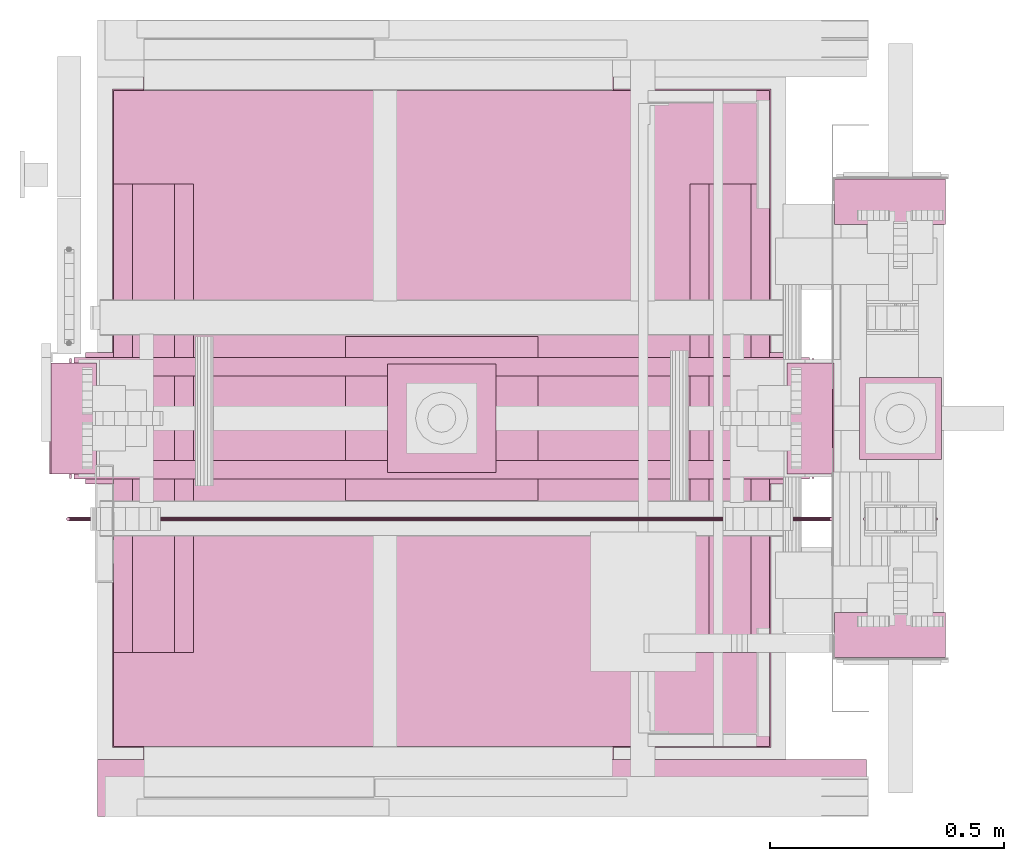
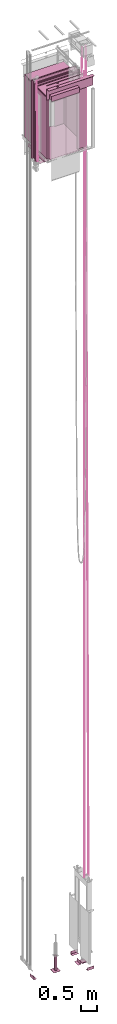
# One storey, part 4 of 13: 5 transport elements.
"""IFC4 building model written with IfcOpenShell, lengths in millimetres."""

from ifc_helpers import new_model, entity, si_unit, converted_unit, frame, origin_with_axes, place, context, subcontext, project, spatial, faceted_brep, element, save


model = new_model("IFC4")

# Units and contexts
context_of_model = context(None, 3, precision=0.01, world=origin_with_axes())
sub_context_1 = subcontext(context_of_model, None, None, "MODEL_VIEW")
sub_context_2 = subcontext(context_of_model, None, None, "MODEL_VIEW")
sub_context_3 = subcontext(context_of_model, None, None, "MODEL_VIEW")
sub_context_4 = subcontext(context_of_model, None, None, "MODEL_VIEW")
sub_context_5 = subcontext(context_of_model, None, None, "MODEL_VIEW")
ifc_project = project(units=[converted_unit("PLANEANGLEUNIT", "degree", entity("IfcPlaneAngleMeasure", 0.017453292519943), si_unit("PLANEANGLEUNIT", "RADIAN"), dimensions=[0, 0, 0, 0, 0, 0, 0]), si_unit("LENGTHUNIT", "METRE", prefix="MILLI"), si_unit("MASSUNIT", "GRAM", prefix="KILO"), converted_unit("TIMEUNIT", "year", entity("IfcTimeMeasure", 31557600.0), si_unit("TIMEUNIT", "SECOND"), dimensions=[0, 0, 1, 0, 0, 0, 0]), si_unit("THERMODYNAMICTEMPERATUREUNIT", "DEGREE_CELSIUS"), si_unit("AREAUNIT", "SQUARE_METRE"), si_unit("FORCEUNIT", "NEWTON"), si_unit("VOLUMEUNIT", "CUBIC_METRE"), si_unit("PRESSUREUNIT", "PASCAL"), si_unit("SOLIDANGLEUNIT", "STERADIAN")], contexts=[context_of_model])

# Site, building, storey
site = spatial("IfcSite", under=ifc_project)
building = spatial("IfcBuilding", under=site, Name="Document")
placement = place(None, origin_with_axes())
storey_placement = place(placement, frame((0.0, 0.0, -26400.0), z_axis=(0.0, 0.0, 1.0), x_axis=(1.0, 0.0, 0.0)))
storey = spatial("IfcBuildingStorey", under=building, at=storey_placement, Name="Z -26400", Elevation=-26400.0)

# Transport elements
transport_element_1_placement = place(storey_placement, frame((900.0, 1025.0, 31219.0), z_axis=(0.0, 0.0, 1.0), x_axis=(1.0, 0.0, 0.0)))
element("IfcTransportElement", 1, at=transport_element_1_placement, inside=storey, ObjectType="Car", PredefinedType="ELEVATOR", context=sub_context_1, shape_type="Brep", body=[
    faceted_brep([(700.0, -700.0, 2300.0), (700.0, 700.0, 2300.0), (700.0, 700.0, 2350.0), (700.0, -700.0, 2350.0), (-700.0, -700.0, 2300.0), (-700.0, -700.0, 2350.0), (-700.0, 700.0, 2350.0), (-700.0, 700.0, 2300.0)], [[[0, 1, 2, 3]], [[4, 5, 6, 7]], [[0, 3, 5, 4]], [[3, 2, 6, 5]], [[2, 1, 7, 6]], [[1, 0, 4, 7]]]),
    faceted_brep([(-636.5, -703.0, 4.0), (-636.5, -703.0, 2300.0), (-703.0, -703.0, 2300.0), (-703.0, -703.0, 4.0), (-703.0, 703.0, 4.0), (-636.5, 703.0, 4.0), (-636.5, 700.0, 4.0), (-700.0, 700.0, 4.0), (-700.0, -700.0, 4.0), (-636.5, -700.0, 4.0), (-703.0, 703.0, 2300.0), (-700.0, -700.0, 2300.0), (-636.5, -700.0, 2300.0), (-700.0, 700.0, 2300.0), (-636.5, 703.0, 2300.0), (-636.5, 700.0, 2300.0)], [[[0, 1, 2, 3]], [[4, 5, 6, 7, 8, 9, 0, 3]], [[2, 10, 4, 3]], [[11, 12, 9, 8]], [[7, 13, 11, 8]], [[9, 12, 1, 0]], [[10, 14, 5, 4]], [[6, 15, 13, 7]], [[5, 14, 15, 6]], [[1, 12, 11, 13, 15, 14, 10, 2]]]),
    faceted_brep([(366.5, -700.0, 4.0), (700.0, -700.0, 4.0), (700.0, 700.0, 4.0), (366.5, 700.0, 4.0), (366.5, 703.0, 4.0), (703.0, 703.0, 4.0), (703.0, -703.0, 4.0), (366.5, -703.0, 4.0), (366.5, -703.0, 2300.0), (366.5, -700.0, 2300.0), (703.0, -703.0, 2300.0), (700.0, -700.0, 2300.0), (700.0, 700.0, 2300.0), (703.0, 703.0, 2300.0), (366.5, 700.0, 2300.0), (366.5, 703.0, 2300.0)], [[[0, 1, 2, 3, 4, 5, 6, 7]], [[8, 9, 0, 7]], [[6, 10, 8, 7]], [[9, 11, 1, 0]], [[11, 12, 2, 1]], [[5, 13, 10, 6]], [[14, 15, 4, 3]], [[2, 12, 14, 3]], [[15, 13, 5, 4]], [[10, 13, 15, 14, 12, 11, 9, 8]]]),
    faceted_brep([(-701.5, -701.5, 4.0), (-701.5, 701.5, 4.0), (-701.5, 701.5, 0.0), (-701.5, -701.5, 0.0), (-636.5, -766.5, 4.0), (-636.5, -701.5, 4.0), (-636.5, -701.5, 0.0), (-636.5, -766.5, 0.0), (-636.5, 701.5, 4.0), (-636.5, 766.5, 4.0), (-636.5, 766.5, 0.0), (-636.5, 701.5, 0.0), (366.5, -701.5, 0.0), (366.5, -701.5, 4.0), (366.5, -766.5, 4.0), (366.5, -766.5, 0.0), (701.5, 701.5, 0.0), (701.5, 701.5, 4.0), (701.5, -701.5, 4.0), (701.5, -701.5, 0.0), (366.5, 766.5, 0.0), (366.5, 766.5, 4.0), (366.5, 701.5, 4.0), (366.5, 701.5, 0.0)], [[[0, 1, 2, 3]], [[4, 5, 6, 7]], [[8, 9, 10, 11]], [[12, 13, 14, 15]], [[16, 17, 18, 19]], [[20, 21, 22, 23]], [[6, 5, 0, 3]], [[15, 14, 4, 7]], [[1, 8, 11, 2]], [[9, 21, 20, 10]], [[19, 18, 13, 12]], [[22, 17, 16, 23]], [[2, 11, 10, 20, 23, 16, 19, 12, 15, 7, 6, 3]], [[5, 4, 14, 13, 18, 17, 22, 21, 9, 8, 1, 0]]]),
])
transport_element_2_placement = place(storey_placement, origin_with_axes())
element("IfcTransportElement", 2, at=transport_element_2_placement, inside=storey, PredefinedType="ELEVATOR", context=sub_context_2, shape_type="Brep", body=[
    faceted_brep([(1647.1722412109375, 807.1715698242188, 30872.0625), (1728.6722412109375, 807.1715698242188, 34609.0625), (1727.805419921875, 808.46923828125, 34609.08203125), (1646.305419921875, 808.46923828125, 30872.080078125), (1646.0009765625, 810.0, 30872.087890625), (1646.305419921875, 811.53076171875, 30872.080078125), (1647.1722412109375, 812.8284301757812, 30872.0625), (1648.4696044921875, 813.6954956054688, 30872.033203125), (1650.0, 814.0, 30872.0), (1651.5303955078125, 813.6954956054688, 30871.966796875), (1652.8277587890625, 812.8284301757812, 30871.9375), (1653.694580078125, 811.53076171875, 30871.919921875), (1653.9990234375, 810.0, 30871.912109375), (1653.694580078125, 808.46923828125, 30871.919921875), (1652.8277587890625, 807.1715698242188, 30871.9375), (1651.5303955078125, 806.3045043945312, 30871.966796875), (1650.0, 806.0, 30872.0), (1648.4696044921875, 806.3045043945312, 30872.033203125), (1727.5009765625, 810.0, 34609.0859375), (1729.9696044921875, 806.3045043945312, 34609.03515625), (1727.805419921875, 811.53076171875, 34609.08203125), (1731.5, 806.0, 34609.0), (1728.6722412109375, 812.8284301757812, 34609.0625), (1733.0303955078125, 806.3045043945312, 34608.96484375), (1729.9696044921875, 813.6954956054688, 34609.03515625), (1734.3277587890625, 807.1715698242188, 34608.9375), (1731.5, 814.0, 34609.0), (1735.194580078125, 808.46923828125, 34608.91796875), (1733.0303955078125, 813.6954956054688, 34608.96484375), (1735.4990234375, 810.0, 34608.9140625), (1734.3277587890625, 812.8284301757812, 34608.9375), (1735.194580078125, 811.53076171875, 34608.91796875)], [[[0, 1, 2, 3]], [[4, 5, 6, 7, 8, 9, 10, 11, 12, 13, 14, 15, 16, 17, 0, 3]], [[2, 18, 4, 3]], [[17, 19, 1, 0]], [[18, 20, 5, 4]], [[16, 21, 19, 17]], [[20, 22, 6, 5]], [[15, 23, 21, 16]], [[22, 24, 7, 6]], [[14, 25, 23, 15]], [[24, 26, 8, 7]], [[13, 27, 25, 14]], [[26, 28, 9, 8]], [[12, 29, 27, 13]], [[28, 30, 10, 9]], [[11, 31, 29, 12]], [[30, 31, 11, 10]], [[1, 19, 21, 23, 25, 27, 29, 31, 30, 28, 26, 24, 22, 20, 18, 2]]]),
    faceted_brep([(1801.171630859375, 807.1715698242188, 3329.0), (1801.171630859375, 807.1715698242188, 33674.0), (1800.304443359375, 808.46923828125, 33674.0), (1800.304443359375, 808.46923828125, 3329.0), (1800.0, 810.0, 3329.0), (1800.304443359375, 811.53076171875, 3329.0), (1801.171630859375, 812.8284301757812, 3329.0), (1802.46923828125, 813.6954956054688, 3329.0), (1804.0, 814.0, 3329.0), (1805.53076171875, 813.6954956054688, 3329.0), (1806.828369140625, 812.8284301757812, 3329.0), (1807.695556640625, 811.53076171875, 3329.0), (1808.0, 810.0, 3329.0), (1807.695556640625, 808.46923828125, 3329.0), (1806.828369140625, 807.1715698242188, 3329.0), (1805.53076171875, 806.3045043945312, 3329.0), (1804.0, 806.0, 3329.0), (1802.46923828125, 806.3045043945312, 3329.0), (1800.0, 810.0, 33674.0), (1802.46923828125, 806.3045043945312, 33674.0), (1800.304443359375, 811.53076171875, 33674.0), (1804.0, 806.0, 33674.0), (1801.171630859375, 812.8284301757812, 33674.0), (1805.53076171875, 806.3045043945312, 33674.0), (1802.46923828125, 813.6954956054688, 33674.0), (1806.828369140625, 807.1715698242188, 33674.0), (1804.0, 814.0, 33674.0), (1807.695556640625, 808.46923828125, 33674.0), (1805.53076171875, 813.6954956054688, 33674.0), (1808.0, 810.0, 33674.0), (1806.828369140625, 812.8284301757812, 33674.0), (1807.695556640625, 811.53076171875, 33674.0)], [[[0, 1, 2, 3]], [[4, 5, 6, 7, 8, 9, 10, 11, 12, 13, 14, 15, 16, 17, 0, 3]], [[2, 18, 4, 3]], [[17, 19, 1, 0]], [[18, 20, 5, 4]], [[16, 21, 19, 17]], [[20, 22, 6, 5]], [[15, 23, 21, 16]], [[22, 24, 7, 6]], [[14, 25, 23, 15]], [[24, 26, 8, 7]], [[13, 27, 25, 14]], [[26, 28, 9, 8]], [[12, 29, 27, 13]], [[28, 30, 10, 9]], [[11, 31, 29, 12]], [[30, 31, 11, 10]], [[1, 19, 21, 23, 25, 27, 29, 31, 30, 28, 26, 24, 22, 20, 18, 2]]]),
    faceted_brep([(1951.171630859375, 807.1715698242188, 3328.9912109375), (1853.671630859375, 807.1715698242188, 34608.9921875), (1852.804443359375, 808.46923828125, 34608.98828125), (1950.304443359375, 808.46923828125, 3328.988525390625), (1950.0, 810.0, 3328.987548828125), (1950.304443359375, 811.53076171875, 3328.988525390625), (1951.171630859375, 812.8284301757812, 3328.9912109375), (1952.46923828125, 813.6954956054688, 3328.9951171875), (1954.0, 814.0, 3329.0), (1955.53076171875, 813.6954956054688, 3329.0048828125), (1956.828369140625, 812.8284301757812, 3329.0087890625), (1957.695556640625, 811.53076171875, 3329.011474609375), (1958.0, 810.0, 3329.012451171875), (1957.695556640625, 808.46923828125, 3329.011474609375), (1956.828369140625, 807.1715698242188, 3329.0087890625), (1955.53076171875, 806.3045043945312, 3329.0048828125), (1954.0, 806.0, 3329.0), (1952.46923828125, 806.3045043945312, 3328.9951171875), (1854.96923828125, 806.3045043945312, 34608.99609375), (1852.5, 810.0, 34608.98828125), (1852.804443359375, 811.53076171875, 34608.98828125), (1856.5, 806.0, 34609.0), (1853.671630859375, 812.8284301757812, 34608.9921875), (1858.03076171875, 806.3045043945312, 34609.00390625), (1854.96923828125, 813.6954956054688, 34608.99609375), (1859.328369140625, 807.1715698242188, 34609.0078125), (1856.5, 814.0, 34609.0), (1860.195556640625, 808.46923828125, 34609.01171875), (1858.03076171875, 813.6954956054688, 34609.00390625), (1860.5, 810.0, 34609.01171875), (1859.328369140625, 812.8284301757812, 34609.0078125), (1860.195556640625, 811.53076171875, 34609.01171875)], [[[0, 1, 2, 3]], [[4, 5, 6, 7, 8, 9, 10, 11, 12, 13, 14, 15, 16, 17, 0, 3]], [[17, 18, 1, 0]], [[2, 19, 4, 3]], [[19, 20, 5, 4]], [[16, 21, 18, 17]], [[20, 22, 6, 5]], [[15, 23, 21, 16]], [[22, 24, 7, 6]], [[14, 25, 23, 15]], [[24, 26, 8, 7]], [[13, 27, 25, 14]], [[26, 28, 9, 8]], [[12, 29, 27, 13]], [[28, 30, 10, 9]], [[30, 31, 11, 10]], [[11, 31, 29, 12]], [[1, 18, 21, 23, 25, 27, 29, 31, 30, 28, 26, 24, 22, 20, 19, 2]]]),
    faceted_brep([(147.1719207763672, 807.1715698242188, 30871.955078125), (100.17192077636719, 807.1715698242188, 33883.95703125), (99.304931640625, 808.46923828125, 33883.94140625), (146.304931640625, 808.46923828125, 30871.94140625), (146.00048828125, 810.0, 30871.9375), (146.304931640625, 811.53076171875, 30871.94140625), (147.1719207763672, 812.8284301757812, 30871.955078125), (148.46945190429688, 813.6954956054688, 30871.9765625), (150.0, 814.0, 30872.0), (151.53054809570312, 813.6954956054688, 30872.0234375), (152.8280792236328, 812.8284301757812, 30872.044921875), (153.695068359375, 811.53076171875, 30872.05859375), (153.99951171875, 810.0, 30872.0625), (153.695068359375, 808.46923828125, 30872.05859375), (152.8280792236328, 807.1715698242188, 30872.044921875), (151.53054809570312, 806.3045043945312, 30872.0234375), (150.0, 806.0, 30872.0), (148.46945190429688, 806.3045043945312, 30871.9765625), (101.46945190429688, 806.3045043945312, 33883.9765625), (99.00048828125, 810.0, 33883.9375), (99.304931640625, 811.53076171875, 33883.94140625), (103.0, 806.0, 33884.0), (100.17192077636719, 812.8284301757812, 33883.95703125), (104.53054809570312, 806.3045043945312, 33884.0234375), (101.46945190429688, 813.6954956054688, 33883.9765625), (105.82807922363281, 807.1715698242188, 33884.04296875), (103.0, 814.0, 33884.0), (106.695068359375, 808.46923828125, 33884.05859375), (104.53054809570312, 813.6954956054688, 33884.0234375), (106.99951171875, 810.0, 33884.0625), (105.82807922363281, 812.8284301757812, 33884.04296875), (106.695068359375, 811.53076171875, 33884.05859375)], [[[0, 1, 2, 3]], [[4, 5, 6, 7, 8, 9, 10, 11, 12, 13, 14, 15, 16, 17, 0, 3]], [[17, 18, 1, 0]], [[2, 19, 4, 3]], [[19, 20, 5, 4]], [[16, 21, 18, 17]], [[20, 22, 6, 5]], [[15, 23, 21, 16]], [[22, 24, 7, 6]], [[14, 25, 23, 15]], [[24, 26, 8, 7]], [[13, 27, 25, 14]], [[26, 28, 9, 8]], [[12, 29, 27, 13]], [[28, 30, 10, 9]], [[30, 31, 11, 10]], [[11, 31, 29, 12]], [[1, 18, 21, 23, 25, 27, 29, 31, 30, 28, 26, 24, 22, 20, 19, 2]]]),
    faceted_brep([(225.0, 808.46923828125, 30788.3046875), (1575.0, 808.46923828125, 30788.3046875), (1575.0, 807.1715698242188, 30789.171875), (225.0, 807.1715698242188, 30789.171875), (225.0, 806.3045043945312, 30790.46875), (225.0, 806.0, 30792.0), (225.0, 806.3045043945312, 30793.53125), (225.0, 807.1715698242188, 30794.828125), (225.0, 808.46923828125, 30795.6953125), (225.0, 810.0, 30796.0), (225.0, 811.53076171875, 30795.6953125), (225.0, 812.8284301757812, 30794.828125), (225.0, 813.6954956054688, 30793.53125), (225.0, 814.0, 30792.0), (225.0, 813.6954956054688, 30790.46875), (225.0, 812.8284301757812, 30789.171875), (225.0, 811.53076171875, 30788.3046875), (225.0, 810.0, 30788.0), (1575.0, 806.3045043945312, 30790.46875), (1575.0, 806.0, 30792.0), (1575.0, 810.0, 30788.0), (1575.0, 806.3045043945312, 30793.53125), (1575.0, 811.53076171875, 30788.3046875), (1575.0, 807.1715698242188, 30794.828125), (1575.0, 812.8284301757812, 30789.171875), (1575.0, 808.46923828125, 30795.6953125), (1575.0, 813.6954956054688, 30790.46875), (1575.0, 810.0, 30796.0), (1575.0, 814.0, 30792.0), (1575.0, 811.53076171875, 30795.6953125), (1575.0, 813.6954956054688, 30793.53125), (1575.0, 812.8284301757812, 30794.828125)], [[[0, 1, 2, 3]], [[4, 5, 6, 7, 8, 9, 10, 11, 12, 13, 14, 15, 16, 17, 0, 3]], [[2, 18, 4, 3]], [[18, 19, 5, 4]], [[17, 20, 1, 0]], [[19, 21, 6, 5]], [[16, 22, 20, 17]], [[21, 23, 7, 6]], [[15, 24, 22, 16]], [[23, 25, 8, 7]], [[14, 26, 24, 15]], [[25, 27, 9, 8]], [[13, 28, 26, 14]], [[27, 29, 10, 9]], [[12, 30, 28, 13]], [[29, 31, 11, 10]], [[11, 31, 30, 12]], [[1, 20, 22, 24, 26, 28, 30, 31, 29, 27, 25, 23, 21, 19, 18, 2]]]),
])
transport_element_3_placement = place(storey_placement, frame((765.0, 175.0, 31219.0), z_axis=(0.0, 0.0, 1.0), x_axis=(1.0, 0.0, 0.0)))
element("IfcTransportElement", 3, at=transport_element_3_placement, inside=storey, PredefinedType="ELEVATOR", context=sub_context_3, shape_type="Brep", body=[
    faceted_brep([(-500.0, 0.0, 2426.0), (-500.0, 119.0, 2426.0), (-500.0, 119.0, 2276.0), (-500.0, 6.0, 2276.0), (-500.0, 6.0, 2226.0), (-500.0, 0.0, 2226.0), (0.0, 6.0, 2226.0), (0.0, 6.0, 2276.0), (0.0, 119.0, 2276.0), (0.0, 119.0, 2426.0), (0.0, 0.0, 2426.0), (0.0, 0.0, 2226.0)], [[[0, 1, 2, 3, 4, 5]], [[6, 7, 8, 9, 10, 11]], [[11, 10, 0, 5]], [[3, 7, 6, 4]], [[1, 9, 8, 2]], [[4, 6, 11, 5]], [[2, 8, 7, 3]], [[10, 9, 1, 0]]]),
    faceted_brep([(-600.0, 119.0, 2663.0), (-600.0, 0.0, 2663.0), (-600.0, 0.0, 2666.0), (-600.0, 122.0, 2666.0), (-600.0, 122.0, 2246.0), (-600.0, 119.0, 2246.0), (1042.0, 122.0, 2246.0), (1042.0, 122.0, 2666.0), (1042.0, 0.0, 2666.0), (1042.0, 0.0, 2663.0), (1042.0, 119.0, 2663.0), (1042.0, 119.0, 2246.0)], [[[0, 1, 2, 3, 4, 5]], [[6, 7, 8, 9, 10, 11]], [[11, 10, 0, 5]], [[3, 7, 6, 4]], [[9, 8, 2, 1]], [[4, 6, 11, 5]], [[0, 10, 9, 1]], [[8, 7, 3, 2]]]),
    faceted_brep([(-600.0, 0.0, 2806.0), (-600.0, 122.0, 2806.0), (-600.0, 122.0, 2786.0), (-600.0, 121.99899291992188, 2786.0), (-600.0, 121.99899291992188, 2806.0), (-600.0, 0.001007080078125, 2786.0), (-600.0, 0.0, 2786.0), (1042.0, 0.001007080078125, 2786.0), (1042.0, 0.001007080078125, 2806.0), (1042.0, 121.99899291992188, 2806.0), (1042.0, 121.99899291992188, 2786.0), (1042.0, 122.0, 2786.0), (1042.0, 122.0, 2806.0), (1042.0, 0.0, 2786.0)], [[[0, 1, 2, 3, 4, 0, 5, 6]], [[7, 8, 9, 10, 11, 12, 8, 13]], [[13, 8, 7, 5, 0, 6]], [[10, 9, 4, 3]], [[1, 12, 11, 2]], [[5, 7, 13, 6]], [[4, 9, 8, 12, 1, 0]], [[2, 11, 10, 3]]]),
    faceted_brep([(-220.0, 64.0, 2691.0), (-222.28363037109375, 75.48049926757812, 2691.0), (-228.78680419921875, 85.21319580078125, 2691.0), (-238.51947021484375, 91.71640014648438, 2691.0), (-250.0, 94.0, 2691.0), (-261.4804992675781, 91.71640014648438, 2691.0), (-271.21319580078125, 85.21319580078125, 2691.0), (-277.7164001464844, 75.48049926757812, 2691.0), (-280.0, 64.0, 2691.0), (-277.7164001464844, 52.519500732421875, 2691.0), (-271.21319580078125, 42.78678894042969, 2691.0), (-261.4804992675781, 36.28361511230469, 2691.0), (-250.0, 34.0, 2691.0), (-238.51947021484375, 36.28361511230469, 2691.0), (-228.78680419921875, 42.78678894042969, 2691.0), (-222.28363037109375, 52.519500732421875, 2691.0), (-220.0, 64.0, 2666.0), (-222.28363037109375, 52.519500732421875, 2666.0), (-228.78680419921875, 42.78678894042969, 2666.0), (-238.51947021484375, 36.28361511230469, 2666.0), (-250.0, 34.0, 2666.0), (-261.4804992675781, 36.28361511230469, 2666.0), (-271.21319580078125, 42.78678894042969, 2666.0), (-277.7164001464844, 52.519500732421875, 2666.0), (-280.0, 64.0, 2666.0), (-277.7164001464844, 75.48049926757812, 2666.0), (-271.21319580078125, 85.21319580078125, 2666.0), (-261.4804992675781, 91.71640014648438, 2666.0), (-250.0, 94.0, 2666.0), (-238.51947021484375, 91.71640014648438, 2666.0), (-228.78680419921875, 85.21319580078125, 2666.0), (-222.28363037109375, 75.48049926757812, 2666.0)], [[[0, 1, 2, 3, 4, 5, 6, 7, 8, 9, 10, 11, 12, 13, 14, 15]], [[16, 17, 18, 19, 20, 21, 22, 23, 24, 25, 26, 27, 28, 29, 30, 31]], [[0, 15, 17, 16]], [[15, 14, 18, 17]], [[14, 13, 19, 18]], [[13, 12, 20, 19]], [[12, 11, 21, 20]], [[11, 10, 22, 21]], [[10, 9, 23, 22]], [[9, 8, 24, 23]], [[8, 7, 25, 24]], [[7, 6, 26, 25]], [[6, 5, 27, 26]], [[5, 4, 28, 27]], [[4, 3, 29, 28]], [[3, 2, 30, 29]], [[2, 1, 31, 30]], [[1, 0, 16, 31]]]),
    faceted_brep([(-220.0, 64.0, 2831.0), (-222.28363037109375, 75.48049926757812, 2831.0), (-228.78680419921875, 85.21319580078125, 2831.0), (-238.51947021484375, 91.71640014648438, 2831.0), (-250.0, 94.0, 2831.0), (-261.4804992675781, 91.71640014648438, 2831.0), (-271.21319580078125, 85.21319580078125, 2831.0), (-277.7164001464844, 75.48049926757812, 2831.0), (-280.0, 64.0, 2831.0), (-277.7164001464844, 52.519500732421875, 2831.0), (-271.21319580078125, 42.78678894042969, 2831.0), (-261.4804992675781, 36.28361511230469, 2831.0), (-250.0, 34.0, 2831.0), (-238.51947021484375, 36.28361511230469, 2831.0), (-228.78680419921875, 42.78678894042969, 2831.0), (-222.28363037109375, 52.519500732421875, 2831.0), (-220.0, 64.0, 2806.0), (-222.28363037109375, 52.519500732421875, 2806.0), (-228.78680419921875, 42.78678894042969, 2806.0), (-238.51947021484375, 36.28361511230469, 2806.0), (-250.0, 34.0, 2806.0), (-261.4804992675781, 36.28361511230469, 2806.0), (-271.21319580078125, 42.78678894042969, 2806.0), (-277.7164001464844, 52.519500732421875, 2806.0), (-280.0, 64.0, 2806.0), (-277.7164001464844, 75.48049926757812, 2806.0), (-271.21319580078125, 85.21319580078125, 2806.0), (-261.4804992675781, 91.71640014648438, 2806.0), (-250.0, 94.0, 2806.0), (-238.51947021484375, 91.71640014648438, 2806.0), (-228.78680419921875, 85.21319580078125, 2806.0), (-222.28363037109375, 75.48049926757812, 2806.0)], [[[0, 1, 2, 3, 4, 5, 6, 7, 8, 9, 10, 11, 12, 13, 14, 15]], [[16, 17, 18, 19, 20, 21, 22, 23, 24, 25, 26, 27, 28, 29, 30, 31]], [[0, 15, 17, 16]], [[15, 14, 18, 17]], [[14, 13, 19, 18]], [[13, 12, 20, 19]], [[12, 11, 21, 20]], [[11, 10, 22, 21]], [[10, 9, 23, 22]], [[9, 8, 24, 23]], [[8, 7, 25, 24]], [[7, 6, 26, 25]], [[6, 5, 27, 26]], [[5, 4, 28, 27]], [[4, 3, 29, 28]], [[3, 2, 30, 29]], [[2, 1, 31, 30]], [[1, 0, 16, 31]]]),
    faceted_brep([(0.0, 0.0, 2426.0), (0.0, 119.0, 2426.0), (0.0, 119.0, 2276.0), (0.0, 6.0, 2276.0), (0.0, 6.0, 2226.0), (0.0, 0.0, 2226.0), (500.0, 6.0, 2226.0), (500.0, 6.0, 2276.0), (500.0, 119.0, 2276.0), (500.0, 119.0, 2426.0), (500.0, 0.0, 2426.0), (500.0, 0.0, 2226.0)], [[[0, 1, 2, 3, 4, 5]], [[6, 7, 8, 9, 10, 11]], [[11, 10, 0, 5]], [[3, 7, 6, 4]], [[1, 9, 8, 2]], [[4, 6, 11, 5]], [[2, 8, 7, 3]], [[10, 9, 1, 0]]]),
])
transport_element_4_placement = place(storey_placement, frame((900.0, 1025.0, 31112.0), z_axis=(0.0, 0.0, 1.0), x_axis=(1.0, 0.0, 0.0)))
element("IfcTransportElement", 4, at=transport_element_4_placement, inside=storey, ObjectType="S5500 Car Frame SL33 2", PredefinedType="ELEVATOR", context=sub_context_4, shape_type="Brep", body=[
    faceted_brep([(-730.0, -110.0, -135.0), (-730.0, 110.0, -135.0), (-730.0, 110.0, -305.0), (-730.0, -110.0, -305.0), (-724.0, 110.0, -305.0), (-724.0, 110.0, -141.0), (-724.0, -110.0, -141.0), (-724.0, -110.0, -305.0), (-560.0, 110.0, -141.0), (-560.0, 110.0, -135.0), (-560.0, -110.0, -135.0), (-560.0, -110.0, -141.0)], [[[0, 1, 2, 3]], [[4, 5, 6, 7]], [[8, 9, 10, 11]], [[7, 6, 11, 10, 0, 3]], [[1, 9, 8, 5, 4, 2]], [[2, 4, 7, 3]], [[10, 9, 1, 0]], [[5, 8, 11, 6]]]),
    faceted_brep([(560.0, -110.0, -135.0), (560.0, 110.0, -135.0), (560.0, 110.0, -141.0), (560.0, -110.0, -141.0), (724.0, -110.0, -141.0), (724.0, 110.0, -141.0), (724.0, 110.0, -305.0), (724.0, -110.0, -305.0), (730.0, 110.0, -305.0), (730.0, 110.0, -135.0), (730.0, -110.0, -135.0), (730.0, -110.0, -305.0)], [[[0, 1, 2, 3]], [[4, 5, 6, 7]], [[8, 9, 10, 11]], [[4, 7, 11, 10, 0, 3]], [[1, 9, 8, 6, 5, 2]], [[2, 5, 4, 3]], [[10, 9, 1, 0]], [[6, 8, 11, 7]]]),
    faceted_brep([(736.0, 48.0, 2617.0), (732.0, 48.0, 2617.0), (732.0, -48.0, 2617.0), (736.0, -48.0, 2617.0), (736.0, 48.0, -317.0), (736.0, -48.0, -317.0), (732.0, -48.0, -317.0), (732.0, 48.0, -317.0)], [[[0, 1, 2, 3]], [[4, 5, 6, 7]], [[0, 3, 5, 4]], [[3, 2, 6, 5]], [[2, 1, 7, 6]], [[1, 0, 4, 7]]]),
    faceted_brep([(732.0, 48.0, 2617.0), (732.0, 90.0, 2617.0), (732.0, 90.0, -317.0), (732.0, 48.0, -317.0), (736.0, 86.0, -317.0), (736.0, 86.0, 2617.0), (736.0, 48.0, 2617.0), (736.0, 48.0, -317.0), (790.0, 90.0, 2617.0), (790.0, 128.0, 2617.0), (790.0, 128.0, -317.0), (790.0, 90.0, -317.0), (794.0, 128.0, -317.0), (794.0, 128.0, 2617.0), (794.0, 86.0, 2617.0), (794.0, 86.0, -317.0)], [[[0, 1, 2, 3]], [[4, 5, 6, 7]], [[8, 9, 10, 11]], [[12, 13, 14, 15]], [[7, 6, 0, 3]], [[1, 8, 11, 2]], [[15, 14, 5, 4]], [[9, 13, 12, 10]], [[2, 11, 10, 12, 15, 4, 7, 3]], [[6, 5, 14, 13, 9, 8, 1, 0]]]),
    faceted_brep([(-785.0, 90.0, 2617.0), (-785.0, 130.0, 2617.0), (-785.0, 130.0, 2611.0), (-785.0, 96.0, 2611.0), (-785.0, 96.0, 2513.0), (-785.0, 130.0, 2513.0), (-785.0, 130.0, 2507.0), (-785.0, 90.0, 2507.0), (785.0, 90.0, 2507.0), (785.0, 130.0, 2507.0), (785.0, 130.0, 2513.0), (785.0, 96.0, 2513.0), (785.0, 96.0, 2611.0), (785.0, 130.0, 2611.0), (785.0, 130.0, 2617.0), (785.0, 90.0, 2617.0)], [[[0, 1, 2, 3, 4, 5, 6, 7]], [[8, 9, 10, 11, 12, 13, 14, 15]], [[8, 15, 0, 7]], [[3, 12, 11, 4]], [[5, 10, 9, 6]], [[1, 14, 13, 2]], [[6, 9, 8, 7]], [[11, 10, 5, 4]], [[15, 14, 1, 0]], [[2, 13, 12, 3]]]),
    faceted_brep([(-700.0, -500.0, -15.0), (-700.0, 500.0, -15.0), (-700.0, 500.0, -135.0), (-700.0, -500.0, -135.0), (-695.0, 500.0, -130.0), (-695.0, 500.0, -20.0), (-695.0, -500.0, -20.0), (-695.0, -500.0, -130.0), (-660.0, 500.0, -20.0), (-660.0, 500.0, -15.0), (-660.0, -500.0, -15.0), (-660.0, -500.0, -20.0), (-535.0, -500.0, -20.0), (-535.0, 500.0, -20.0), (-535.0, 500.0, -130.0), (-535.0, -500.0, -130.0), (-530.0, 500.0, -135.0), (-530.0, 500.0, -15.0), (-530.0, -500.0, -15.0), (-530.0, -500.0, -135.0), (-570.0, -500.0, -15.0), (-570.0, 500.0, -15.0), (-570.0, 500.0, -20.0), (-570.0, -500.0, -20.0)], [[[0, 1, 2, 3]], [[4, 5, 6, 7]], [[8, 9, 10, 11]], [[12, 13, 14, 15]], [[16, 17, 18, 19]], [[20, 21, 22, 23]], [[19, 18, 20, 23, 12, 15, 7, 6, 11, 10, 0, 3]], [[2, 1, 9, 8, 5, 4, 14, 13, 22, 21, 17, 16]], [[2, 16, 19, 3]], [[15, 14, 4, 7]], [[10, 9, 1, 0]], [[5, 8, 11, 6]], [[22, 13, 12, 23]], [[18, 17, 21, 20]]]),
    faceted_brep([(-760.0, -140.0, -297.0), (-760.0, -110.0, -297.0), (-760.0, -110.0, -317.0), (-760.0, -140.0, -317.0), (-710.0, -110.0, -297.0), (-710.0, 110.0, -297.0), (-710.0, 110.0, -317.0), (-710.0, -110.0, -317.0), (-610.0, 140.0, -317.0), (-610.0, 140.0, -297.0), (-610.0, -140.0, -297.0), (-610.0, -140.0, -317.0), (-760.0, 110.0, -297.0), (-760.0, 140.0, -297.0), (-760.0, 140.0, -317.0), (-760.0, 110.0, -317.0)], [[[0, 1, 2, 3]], [[4, 5, 6, 7]], [[8, 9, 10, 11]], [[12, 13, 14, 15]], [[11, 10, 0, 3]], [[1, 4, 7, 2]], [[6, 5, 12, 15]], [[13, 9, 8, 14]], [[2, 7, 6, 15, 14, 8, 11, 3]], [[10, 9, 13, 12, 5, 4, 1, 0]]]),
    faceted_brep([(530.0, -500.0, -15.0), (530.0, 500.0, -15.0), (530.0, 500.0, -135.0), (530.0, -500.0, -135.0), (535.0, 500.0, -130.0), (535.0, 500.0, -20.0), (535.0, -500.0, -20.0), (535.0, -500.0, -130.0), (570.0, 500.0, -20.0), (570.0, 500.0, -15.0), (570.0, -500.0, -15.0), (570.0, -500.0, -20.0), (695.0, -500.0, -20.0), (695.0, 500.0, -20.0), (695.0, 500.0, -130.0), (695.0, -500.0, -130.0), (700.0, 500.0, -135.0), (700.0, 500.0, -15.0), (700.0, -500.0, -15.0), (700.0, -500.0, -135.0), (660.0, -500.0, -15.0), (660.0, 500.0, -15.0), (660.0, 500.0, -20.0), (660.0, -500.0, -20.0)], [[[0, 1, 2, 3]], [[4, 5, 6, 7]], [[8, 9, 10, 11]], [[12, 13, 14, 15]], [[16, 17, 18, 19]], [[20, 21, 22, 23]], [[19, 18, 20, 23, 12, 15, 7, 6, 11, 10, 0, 3]], [[2, 1, 9, 8, 5, 4, 14, 13, 22, 21, 17, 16]], [[2, 16, 19, 3]], [[15, 14, 4, 7]], [[10, 9, 1, 0]], [[5, 8, 11, 6]], [[22, 13, 12, 23]], [[18, 17, 21, 20]]]),
    faceted_brep([(-732.0, 48.0, 2617.0), (-736.0, 48.0, 2617.0), (-736.0, -48.0, 2617.0), (-732.0, -48.0, 2617.0), (-732.0, 48.0, -317.0), (-732.0, -48.0, -317.0), (-736.0, -48.0, -317.0), (-736.0, 48.0, -317.0)], [[[0, 1, 2, 3]], [[4, 5, 6, 7]], [[0, 3, 5, 4]], [[3, 2, 6, 5]], [[2, 1, 7, 6]], [[1, 0, 4, 7]]]),
    faceted_brep([(732.0, -90.0, 2617.0), (732.0, -48.0, 2617.0), (732.0, -48.0, -317.0), (732.0, -90.0, -317.0), (736.0, -48.0, -317.0), (736.0, -48.0, 2617.0), (736.0, -86.0, 2617.0), (736.0, -86.0, -317.0), (790.0, -128.0, 2617.0), (790.0, -90.0, 2617.0), (790.0, -90.0, -317.0), (790.0, -128.0, -317.0), (794.0, -86.0, -317.0), (794.0, -86.0, 2617.0), (794.0, -128.0, 2617.0), (794.0, -128.0, -317.0)], [[[0, 1, 2, 3]], [[4, 5, 6, 7]], [[8, 9, 10, 11]], [[12, 13, 14, 15]], [[10, 9, 0, 3]], [[6, 13, 12, 7]], [[1, 5, 4, 2]], [[15, 14, 8, 11]], [[3, 2, 4, 7, 12, 15, 11, 10]], [[9, 8, 14, 13, 6, 5, 1, 0]]]),
    faceted_brep([(610.0, -140.0, -297.0), (610.0, 140.0, -297.0), (610.0, 140.0, -317.0), (610.0, -140.0, -317.0), (710.0, 110.0, -317.0), (710.0, 110.0, -297.0), (710.0, -110.0, -297.0), (710.0, -110.0, -317.0), (760.0, -110.0, -317.0), (760.0, -110.0, -297.0), (760.0, -140.0, -297.0), (760.0, -140.0, -317.0), (760.0, 140.0, -317.0), (760.0, 140.0, -297.0), (760.0, 110.0, -297.0), (760.0, 110.0, -317.0)], [[[0, 1, 2, 3]], [[4, 5, 6, 7]], [[8, 9, 10, 11]], [[12, 13, 14, 15]], [[11, 10, 0, 3]], [[6, 9, 8, 7]], [[1, 13, 12, 2]], [[15, 14, 5, 4]], [[2, 12, 15, 4, 7, 8, 11, 3]], [[0, 10, 9, 6, 5, 14, 13, 1]]]),
    faceted_brep([(-785.0, -130.0, 2513.0), (-785.0, -96.0, 2513.0), (-785.0, -96.0, 2611.0), (-785.0, -130.0, 2611.0), (-785.0, -130.0, 2617.0), (-785.0, -90.0, 2617.0), (-785.0, -90.0, 2507.0), (-785.0, -130.0, 2507.0), (785.0, -90.0, 2507.0), (785.0, -90.0, 2617.0), (785.0, -130.0, 2617.0), (785.0, -130.0, 2611.0), (785.0, -96.0, 2611.0), (785.0, -96.0, 2513.0), (785.0, -130.0, 2513.0), (785.0, -130.0, 2507.0)], [[[0, 1, 2, 3, 4, 5, 6, 7]], [[8, 9, 10, 11, 12, 13, 14, 15]], [[15, 14, 0, 7]], [[13, 12, 2, 1]], [[5, 9, 8, 6]], [[11, 10, 4, 3]], [[6, 8, 15, 7]], [[14, 13, 1, 0]], [[2, 12, 11, 3]], [[10, 9, 5, 4]]]),
    faceted_brep([(-794.0, 86.0, 2617.0), (-794.0, 128.0, 2617.0), (-794.0, 128.0, -317.0), (-794.0, 86.0, -317.0), (-790.0, 128.0, -317.0), (-790.0, 128.0, 2617.0), (-790.0, 90.0, 2617.0), (-790.0, 90.0, -317.0), (-736.0, 48.0, 2617.0), (-736.0, 86.0, 2617.0), (-736.0, 86.0, -317.0), (-736.0, 48.0, -317.0), (-732.0, 90.0, -317.0), (-732.0, 90.0, 2617.0), (-732.0, 48.0, 2617.0), (-732.0, 48.0, -317.0)], [[[0, 1, 2, 3]], [[4, 5, 6, 7]], [[8, 9, 10, 11]], [[12, 13, 14, 15]], [[10, 9, 0, 3]], [[6, 13, 12, 7]], [[1, 5, 4, 2]], [[15, 14, 8, 11]], [[2, 4, 7, 12, 15, 11, 10, 3]], [[0, 9, 8, 14, 13, 6, 5, 1]]]),
    faceted_brep([(-794.0, -128.0, 2617.0), (-794.0, -86.0, 2617.0), (-794.0, -86.0, -317.0), (-794.0, -128.0, -317.0), (-790.0, -90.0, -317.0), (-790.0, -90.0, 2617.0), (-790.0, -128.0, 2617.0), (-790.0, -128.0, -317.0), (-736.0, -86.0, 2617.0), (-736.0, -48.0, 2617.0), (-736.0, -48.0, -317.0), (-736.0, -86.0, -317.0), (-732.0, -48.0, -317.0), (-732.0, -48.0, 2617.0), (-732.0, -90.0, 2617.0), (-732.0, -90.0, -317.0)], [[[0, 1, 2, 3]], [[4, 5, 6, 7]], [[8, 9, 10, 11]], [[12, 13, 14, 15]], [[7, 6, 0, 3]], [[1, 8, 11, 2]], [[15, 14, 5, 4]], [[9, 13, 12, 10]], [[2, 11, 10, 12, 15, 4, 7, 3]], [[6, 5, 14, 13, 9, 8, 1, 0]]]),
    faceted_brep([(-205.0, -175.0, -168.0), (-205.0, 175.0, -168.0), (-205.0, 175.0, -178.0), (-205.0, -175.0, -178.0), (205.0, -175.0, -168.0), (205.0, -175.0, -178.0), (205.0, 175.0, -178.0), (205.0, 175.0, -168.0)], [[[0, 1, 2, 3]], [[4, 5, 6, 7]], [[0, 3, 5, 4]], [[3, 2, 6, 5]], [[2, 1, 7, 6]], [[1, 0, 4, 7]]]),
])
transport_element_5_placement = place(storey_placement, frame((900.0, 1025.0, 0.0), z_axis=(0.0, 0.0, 1.0), x_axis=(1.0, 0.0, 0.0)))
element("IfcTransportElement", 5, at=transport_element_5_placement, inside=storey, PredefinedType="ELEVATOR", context=sub_context_5, shape_type="Brep", body=[
    faceted_brep([(838.0, -514.0, 0.0), (838.0, -514.0, 110.0), (838.0, -511.0, 110.0), (838.0, -511.0, 3.0), (838.0, -414.0, 3.0), (838.0, -414.0, 0.0), (1075.0, -414.0, 0.0), (1075.0, -414.0, 3.0), (1075.0, -511.0, 3.0), (1075.0, -511.0, 110.0), (1075.0, -514.0, 110.0), (1075.0, -514.0, 0.0)], [[[0, 1, 2, 3, 4, 5]], [[6, 7, 8, 9, 10, 11]], [[11, 10, 1, 0]], [[2, 9, 8, 3]], [[4, 7, 6, 5]], [[5, 6, 11, 0]], [[8, 7, 4, 3]], [[10, 9, 2, 1]]]),
    faceted_brep([(737.0, -118.5, 3.0), (737.0, 118.5, 3.0), (737.0, 118.5, 0.0), (737.0, -118.5, 0.0), (834.0, -118.5, 110.0), (834.0, 118.5, 110.0), (834.0, 118.5, 3.0), (834.0, -118.5, 3.0), (837.0, 118.5, 0.0), (837.0, 118.5, 110.0), (837.0, -118.5, 110.0), (837.0, -118.5, 0.0)], [[[0, 1, 2, 3]], [[4, 5, 6, 7]], [[8, 9, 10, 11]], [[11, 10, 4, 7, 0, 3]], [[1, 6, 5, 9, 8, 2]], [[2, 8, 11, 3]], [[7, 6, 1, 0]], [[10, 9, 5, 4]]]),
    faceted_brep([(1014.0, 35.0, 15.0), (944.0, 35.0, 15.0), (944.0, -35.0, 15.0), (1014.0, -35.0, 15.0), (1014.0, 35.0, -16.0), (1014.0, -35.0, -16.0), (944.0, -35.0, -16.0), (944.0, 35.0, -16.0)], [[[0, 1, 2, 3]], [[4, 5, 6, 7]], [[0, 3, 5, 4]], [[3, 2, 6, 5]], [[2, 1, 7, 6]], [[1, 0, 4, 7]]]),
    faceted_brep([(838.0, 414.0, 3.0), (838.0, 511.0, 3.0), (838.0, 511.0, 110.0), (838.0, 514.0, 110.0), (838.0, 514.0, 0.0), (838.0, 414.0, 0.0), (1075.0, 514.0, 0.0), (1075.0, 514.0, 110.0), (1075.0, 511.0, 110.0), (1075.0, 511.0, 3.0), (1075.0, 414.0, 3.0), (1075.0, 414.0, 0.0)], [[[0, 1, 2, 3, 4, 5]], [[6, 7, 8, 9, 10, 11]], [[11, 10, 0, 5]], [[9, 8, 2, 1]], [[3, 7, 6, 4]], [[4, 6, 11, 5]], [[10, 9, 1, 0]], [[8, 7, 3, 2]]]),
    faceted_brep([(-837.0, -118.5, 110.0), (-837.0, 118.5, 110.0), (-837.0, 118.5, 0.0), (-837.0, -118.5, 0.0), (-834.0, 118.5, 3.0), (-834.0, 118.5, 110.0), (-834.0, -118.5, 110.0), (-834.0, -118.5, 3.0), (-737.0, 118.5, 0.0), (-737.0, 118.5, 3.0), (-737.0, -118.5, 3.0), (-737.0, -118.5, 0.0)], [[[0, 1, 2, 3]], [[4, 5, 6, 7]], [[8, 9, 10, 11]], [[11, 10, 7, 6, 0, 3]], [[2, 1, 5, 4, 9, 8]], [[2, 8, 11, 3]], [[10, 9, 4, 7]], [[6, 5, 1, 0]]]),
    faceted_brep([(1066.5, 87.5, 15.0), (1066.5, -87.5, 15.0), (1066.5, -87.5, 0.0), (1066.5, 87.5, 0.0), (891.5, 87.5, 15.0), (891.5, 87.5, 0.0), (891.5, -87.5, 0.0), (891.5, -87.5, 15.0)], [[[0, 1, 2, 3]], [[4, 5, 6, 7]], [[0, 3, 5, 4]], [[3, 2, 6, 5]], [[2, 1, 7, 6]], [[1, 0, 4, 7]]]),
    faceted_brep([(891.5, -87.5, 0.0), (891.5, 87.5, 0.0), (891.5, 87.5, -16.0), (891.5, -87.5, -16.0), (1066.5, -87.5, 0.0), (1066.5, -87.5, -16.0), (1066.5, 87.5, -16.0), (1066.5, 87.5, 0.0)], [[[0, 1, 2, 3]], [[4, 5, 6, 7]], [[0, 3, 5, 4]], [[3, 2, 6, 5]], [[2, 1, 7, 6]], [[1, 0, 4, 7]]]),
    faceted_brep([(115.5, 115.5, 10.0), (115.5, -115.5, 10.0), (115.5, -115.5, 0.0), (115.5, 115.5, 0.0), (-115.5, 115.5, 10.0), (-115.5, 115.5, 0.0), (-115.5, -115.5, 0.0), (-115.5, -115.5, 10.0)], [[[0, 1, 2, 3]], [[4, 5, 6, 7]], [[0, 3, 5, 4]], [[3, 2, 6, 5]], [[2, 1, 7, 6]], [[1, 0, 4, 7]]]),
    faceted_brep([(35.0, 35.0, 577.0), (-35.0, 35.0, 577.0), (-35.0, -35.0, 577.0), (35.0, -35.0, 577.0), (35.0, 35.0, 10.0), (35.0, -35.0, 10.0), (-35.0, -35.0, 10.0), (-35.0, 35.0, 10.0)], [[[0, 1, 2, 3]], [[4, 5, 6, 7]], [[0, 3, 5, 4]], [[3, 2, 6, 5]], [[2, 1, 7, 6]], [[1, 0, 4, 7]]]),
])

save(model, "model.ifc")
